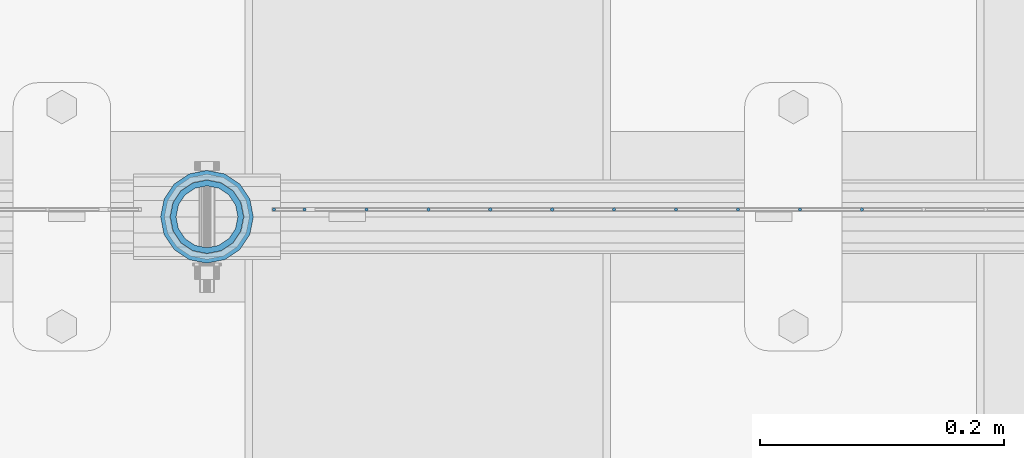
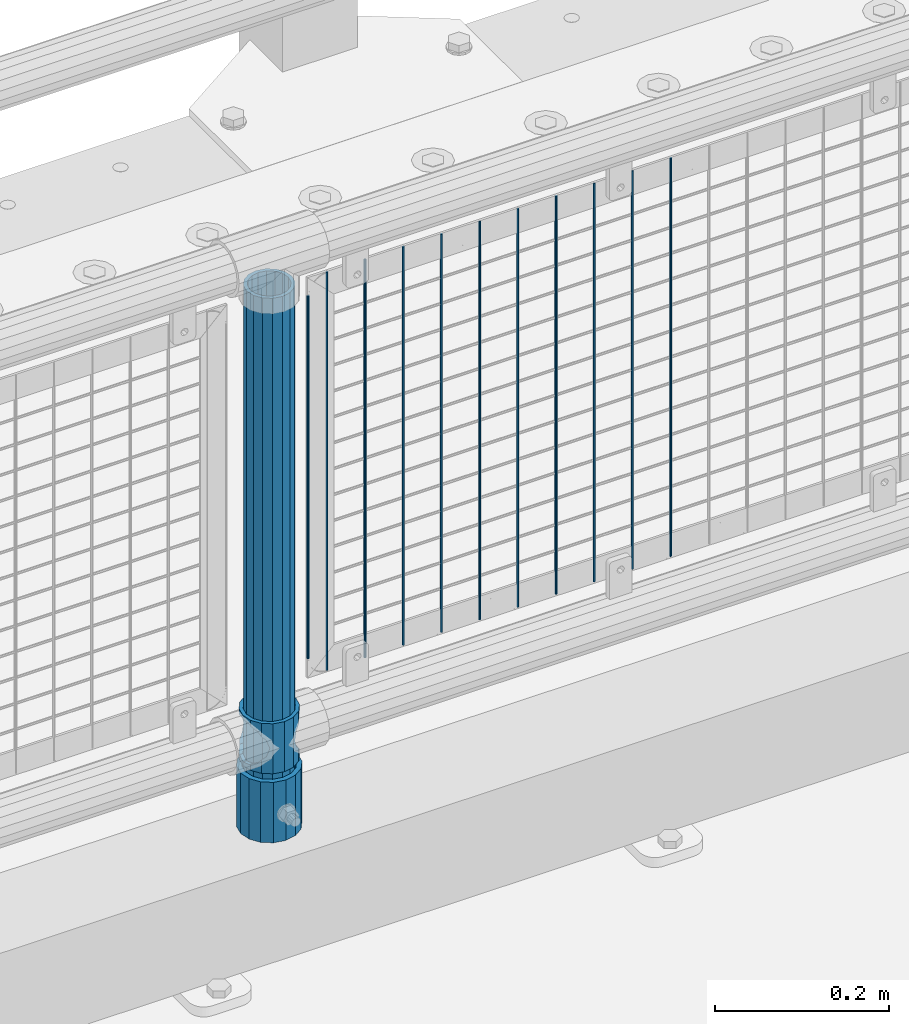
# One storey, part 88 of 270: 14 columns.
"""IFC2X3 building model written with IfcOpenShell, lengths in millimetres."""

from ifc_helpers import new_model, si_unit, frame, origin_with_axes, place, context, subcontext, project, spatial, faceted_brep, material, type_object, element, save


model = new_model("IFC2X3")

# Units and contexts
model_context = context("Model", 3, precision=1e-05, world=origin_with_axes())
body_context = subcontext(model_context, "Body", "Model", "MODEL_VIEW")
ifc_project = project(units=[si_unit("LENGTHUNIT", "METRE", prefix="MILLI"), si_unit("AREAUNIT", "SQUARE_METRE"), si_unit("VOLUMEUNIT", "CUBIC_METRE"), si_unit("MASSUNIT", "GRAM", prefix="KILO"), si_unit("TIMEUNIT", "SECOND"), si_unit("PLANEANGLEUNIT", "RADIAN"), si_unit("SOLIDANGLEUNIT", "STERADIAN"), si_unit("THERMODYNAMICTEMPERATUREUNIT", "DEGREE_CELSIUS"), si_unit("LUMINOUSINTENSITYUNIT", "LUMEN")], contexts=[model_context])

# Site, building, storey
site_placement = place(None, origin_with_axes())
site = spatial("IfcSite", under=ifc_project, at=site_placement, CompositionType="ELEMENT")
building_placement = place(site_placement, origin_with_axes())
building = spatial("IfcBuilding", under=site, at=building_placement, Name="Standard", CompositionType="ELEMENT")
storey_placement = place(building_placement, origin_with_axes())
storey = spatial("IfcBuildingStorey", under=building, at=storey_placement, Name="Undefined", CompositionType="ELEMENT", Elevation=0.0)

# Columns
ifc_material_1 = material()
column_type_1 = type_object("IfcColumnType", PredefinedType="NOTDEFINED")
column_1_placement = place(storey_placement, frame((10419.0, -16335.5, 168.02), z_axis=(-1.0, 0.0, 0.0), x_axis=(0.0, 0.0, 1.0)))
element("IfcColumn", 1, at=column_1_placement, inside=storey, type_object=column_type_1, material=ifc_material_1, context=body_context, shape_type="Brep", body=[
    faceted_brep([(0.0, -25.3500000000004, 0.0), (0.0, -23.4203461491616, 9.70102501045403), (760.0, -23.4203461491616, 9.70102501045403), (760.0, -25.3500000000004, 0.0), (0.0, -17.9251569030785, 17.9251569030785), (760.0, -17.9251569030785, 17.9251569030785), (0.0, -9.70102501045585, 23.4203461491597), (760.0, -9.70102501045585, 23.4203461491597), (0.0, 0.0, 25.3499999999985), (760.0, 0.0, 25.3499999999985), (0.0, 9.70102501045585, 23.4203461491597), (760.0, 9.70102501045585, 23.4203461491597), (0.0, 17.9251569030785, 17.9251569030785), (760.0, 17.9251569030785, 17.9251569030785), (0.0, 23.4203461491616, 9.70102501045403), (760.0, 23.4203461491616, 9.70102501045403), (0.0, 25.3500000000004, 0.0), (760.0, 25.3500000000004, 0.0), (0.0, 23.4203461491616, -9.70102501045403), (760.0, 23.4203461491616, -9.70102501045403), (0.0, 17.9251569030785, -17.9251569030785), (760.0, 17.9251569030785, -17.9251569030785), (0.0, 9.70102501045585, -23.4203461491597), (760.0, 9.70102501045585, -23.4203461491597), (0.0, 0.0, -25.3499999999985), (760.0, 0.0, -25.3499999999985), (0.0, -9.70102501045585, -23.4203461491597), (760.0, -9.70102501045585, -23.4203461491597), (0.0, -17.9251569030785, -17.9251569030785), (760.0, -17.9251569030785, -17.9251569030785), (0.0, -23.4203461491616, -9.70102501045403), (760.0, -23.4203461491616, -9.70102501045403), (0.0, -30.1499999999996, 0.0), (0.0, -27.8549679052157, -11.5379054858058), (760.0, -27.8549679052157, -11.5379054858058), (760.0, -30.1499999999996, 0.0), (0.0, -21.3192694527752, -21.3192694527752), (760.0, -21.3192694527752, -21.3192694527752), (0.0, -11.5379054858076, -27.8549679052157), (760.0, -11.5379054858076, -27.8549679052157), (0.0, 0.0, -30.1500000000015), (760.0, 0.0, -30.1500000000015), (0.0, 11.5379054858076, -27.8549679052157), (760.0, 11.5379054858076, -27.8549679052157), (0.0, 21.3192694527752, -21.3192694527752), (760.0, 21.3192694527752, -21.3192694527752), (0.0, 27.8549679052157, -11.5379054858058), (760.0, 27.8549679052157, -11.5379054858058), (0.0, 30.1499999999996, 0.0), (760.0, 30.1499999999996, 0.0), (0.0, 27.8549679052157, 11.5379054858058), (760.0, 27.8549679052157, 11.5379054858058), (0.0, 21.3192694527752, 21.3192694527752), (760.0, 21.3192694527752, 21.3192694527752), (0.0, 11.5379054858076, 27.8549679052157), (760.0, 11.5379054858076, 27.8549679052157), (0.0, 0.0, 30.1500000000015), (760.0, 0.0, 30.1500000000015), (0.0, -11.5379054858076, 27.8549679052157), (760.0, -11.5379054858076, 27.8549679052157), (0.0, -21.3192694527752, 21.3192694527752), (760.0, -21.3192694527752, 21.3192694527752), (0.0, -27.8549679052157, 11.5379054858058), (760.0, -27.8549679052157, 11.5379054858058)], [[[0, 1, 2, 3]], [[1, 4, 5, 2]], [[4, 6, 7, 5]], [[6, 8, 9, 7]], [[8, 10, 11, 9]], [[10, 12, 13, 11]], [[12, 14, 15, 13]], [[14, 16, 17, 15]], [[16, 18, 19, 17]], [[18, 20, 21, 19]], [[20, 22, 23, 21]], [[22, 24, 25, 23]], [[24, 26, 27, 25]], [[26, 28, 29, 27]], [[28, 30, 31, 29]], [[30, 0, 3, 31]], [[32, 33, 34, 35]], [[33, 36, 37, 34]], [[36, 38, 39, 37]], [[38, 40, 41, 39]], [[40, 42, 43, 41]], [[42, 44, 45, 43]], [[44, 46, 47, 45]], [[46, 48, 49, 47]], [[48, 50, 51, 49]], [[50, 52, 53, 51]], [[52, 54, 55, 53]], [[54, 56, 57, 55]], [[56, 58, 59, 57]], [[58, 60, 61, 59]], [[60, 62, 63, 61]], [[62, 32, 35, 63]], [[37, 39, 41, 43, 45, 47, 49, 51, 53, 55, 57, 59, 61, 63, 35, 34], [5, 7, 9, 11, 13, 15, 17, 19, 21, 23, 25, 27, 29, 31, 3, 2]], [[62, 60, 58, 56, 54, 52, 50, 48, 46, 44, 42, 40, 38, 36, 33, 32], [30, 28, 26, 24, 22, 20, 18, 16, 14, 12, 10, 8, 6, 4, 1, 0]]]),
])
column_type_2 = type_object("IfcColumnType", PredefinedType="NOTDEFINED")
column_2_placement = place(storey_placement, frame((10419.0, -16335.5, 168.02), z_axis=(0.0, 1.0, 0.0), x_axis=(0.0, 0.0, 1.0)))
element("IfcColumn", 2, at=column_2_placement, inside=storey, type_object=column_type_2, material=ifc_material_1, context=body_context, shape_type="Brep", body=[
    faceted_brep([(0.0, -31.75, 0.0), (0.0, -29.3331751572332, 12.1501989775916), (85.0, -29.3331751572332, 12.1501989775916), (85.0, -31.75, 0.0), (0.0, -22.4506403026717, 22.4506403026735), (85.0, -22.4506403026717, 22.4506403026735), (0.0, -12.1501989775934, 29.3331751572332), (85.0, -12.1501989775934, 29.3331751572332), (0.0, 0.0, 31.75), (85.0, 0.0, 31.75), (0.0, 12.1501989775934, 29.3331751572332), (85.0, 12.1501989775934, 29.3331751572332), (0.0, 22.4506403026717, 22.4506403026735), (85.0, 22.4506403026717, 22.4506403026735), (0.0, 29.3331751572332, 12.1501989775916), (85.0, 29.3331751572332, 12.1501989775916), (0.0, 31.75, 0.0), (85.0, 31.75, 0.0), (0.0, 29.3331751572332, -12.1501989775916), (85.0, 29.3331751572332, -12.1501989775916), (0.0, 22.4506403026717, -22.4506403026735), (85.0, 22.4506403026717, -22.4506403026735), (0.0, 12.1501989775934, -29.3331751572332), (85.0, 12.1501989775934, -29.3331751572332), (0.0, 0.0, -31.75), (85.0, 0.0, -31.75), (0.0, -12.1501989775934, -29.3331751572332), (85.0, -12.1501989775934, -29.3331751572332), (0.0, -22.4506403026717, -22.4506403026735), (85.0, -22.4506403026717, -22.4506403026735), (0.0, -29.3331751572332, -12.1501989775916), (85.0, -29.3331751572332, -12.1501989775916), (0.0, -38.0499999999993, 0.0), (0.0, -35.1536162120537, -14.561104601491), (85.0, -35.1536162120537, -14.561104601491), (85.0, -38.0499999999993, 0.0), (0.0, -26.9054130241493, -26.9054130241475), (85.0, -26.9054130241493, -26.9054130241475), (0.0, -14.5611046014928, -35.1536162120537), (85.0, -14.5611046014928, -35.1536162120537), (0.0, 0.0, -38.0499999999993), (85.0, 0.0, -38.0499999999993), (0.0, 14.5611046014928, -35.1536162120537), (85.0, 14.5611046014928, -35.1536162120537), (0.0, 26.9054130241493, -26.9054130241475), (85.0, 26.9054130241493, -26.9054130241475), (0.0, 35.1536162120537, -14.561104601491), (85.0, 35.1536162120537, -14.561104601491), (0.0, 38.0499999999993, 0.0), (85.0, 38.0499999999993, 0.0), (0.0, 35.1536162120537, 14.561104601491), (85.0, 35.1536162120537, 14.561104601491), (0.0, 26.9054130241493, 26.9054130241475), (85.0, 26.9054130241493, 26.9054130241475), (0.0, 14.5611046014928, 35.1536162120537), (85.0, 14.5611046014928, 35.1536162120537), (0.0, 0.0, 38.0499999999993), (85.0, 0.0, 38.0499999999993), (0.0, -14.5611046014928, 35.1536162120537), (85.0, -14.5611046014928, 35.1536162120537), (0.0, -26.9054130241493, 26.9054130241475), (85.0, -26.9054130241493, 26.9054130241475), (0.0, -35.1536162120537, 14.561104601491), (85.0, -35.1536162120537, 14.561104601491)], [[[0, 1, 2, 3]], [[1, 4, 5, 2]], [[4, 6, 7, 5]], [[6, 8, 9, 7]], [[8, 10, 11, 9]], [[10, 12, 13, 11]], [[12, 14, 15, 13]], [[14, 16, 17, 15]], [[16, 18, 19, 17]], [[18, 20, 21, 19]], [[20, 22, 23, 21]], [[22, 24, 25, 23]], [[24, 26, 27, 25]], [[26, 28, 29, 27]], [[28, 30, 31, 29]], [[30, 0, 3, 31]], [[32, 33, 34, 35]], [[33, 36, 37, 34]], [[36, 38, 39, 37]], [[38, 40, 41, 39]], [[40, 42, 43, 41]], [[42, 44, 45, 43]], [[44, 46, 47, 45]], [[46, 48, 49, 47]], [[48, 50, 51, 49]], [[50, 52, 53, 51]], [[52, 54, 55, 53]], [[54, 56, 57, 55]], [[56, 58, 59, 57]], [[58, 60, 61, 59]], [[60, 62, 63, 61]], [[62, 32, 35, 63]], [[37, 39, 41, 43, 45, 47, 49, 51, 53, 55, 57, 59, 61, 63, 35, 34], [5, 7, 9, 11, 13, 15, 17, 19, 21, 23, 25, 27, 29, 31, 3, 2]], [[62, 60, 58, 56, 54, 52, 50, 48, 46, 44, 42, 40, 38, 36, 33, 32], [30, 28, 26, 24, 22, 20, 18, 16, 14, 12, 10, 8, 6, 4, 1, 0]]]),
])
ifc_material_2 = material(Name="Misc_Undefined")
column_type_3 = type_object("IfcColumnType", PredefinedType="NOTDEFINED")
column_3_placement = place(storey_placement, frame((10419.0, -16335.5, 263.02), z_axis=(-1.0, 0.0, 0.0), x_axis=(0.0, 0.0, 1.0)))
element("IfcColumn", 3, at=column_3_placement, inside=storey, type_object=column_type_3, material=ifc_material_2, context=body_context, shape_type="Brep", body=[
    faceted_brep([(63.1897438117183, 11.6144421722802, -32.8397438117208), (63.1897438117183, 11.6144421722802, -28.0397438117179), (56.6106908090125, 21.4606908090118, -21.46069080901), (56.6106908090125, 21.4606908090118, -27.1226768591005), (61.9623795176767, 13.4513226476338, -32.4743655677703), (46.7644421722812, 28.0397438117179, -11.614442172282), (46.7644421722812, 28.0397438117179, -20.0882031229812), (51.5310424080071, 24.8548033587067, -24.8548033587067), (35.1500000000015, 30.35, 0.0), (35.1500000000008, 30.3500000000004, -16.6306603983612), (23.5355578277203, 28.0397438117179, -11.614442172282), (23.5355578277203, 28.0397438117179, -20.0882031229812), (18.7689575919954, 24.8548033587067, -24.8548033587067), (13.689309190989, 21.4606908090118, -21.46069080901), (13.689309190989, 21.4606908090118, -27.1226768591005), (8.33762048232484, 13.4513226476338, -32.4743655677703), (7.11025618828324, 11.6144421722802, -28.0397438117179), (7.11025618828324, 11.6144421722802, -32.8397438117208), (4.80000000000075, 0.0, -30.3499999999985), (4.80000000000075, 0.0, -35.1500000000015), (7.11025618828319, -11.6144421722802, -28.0397438117179), (7.11025618828319, -11.6144421722802, -32.8397438117172), (13.689309190989, -21.4606908090118, -21.46069080901), (13.689309190989, -21.4606908090118, -27.1226768591041), (8.33762048232484, -13.4513226476338, -32.4743655677703), (23.5355578277203, -28.0397438117179, -11.614442172282), (23.5355578277203, -28.0397438117179, -20.0882031229885), (18.7689575919954, -24.8548033587067, -24.8548033587067), (35.1500000000015, -30.35, 0.0), (35.1500000000008, -30.3500000000004, -16.6306603983721), (46.7644421722812, -28.0397438117179, -11.614442172282), (46.7644421722812, -28.0397438117179, -20.0882031229885), (51.5310424080071, -24.8548033587067, -24.8548033587067), (56.6106908090125, -21.4606908090118, -21.46069080901), (56.6106908090125, -21.4606908090118, -27.1226768591041), (61.9623795176767, -13.4513226476338, -32.4743655677703), (63.1897438117183, -11.6144421722802, -28.0397438117179), (63.1897438117183, -11.6144421722802, -32.8397438117172), (65.5000000000008, 0.0, -30.3499999999985), (65.5000000000008, 0.0, -35.1500000000015), (0.0, -28.0397438117179, -11.614442172282), (0.0, -30.3500000000004, 0.0), (0.0, -21.4606908090118, -21.46069080901), (0.0, -11.6144421722802, -28.0397438117179), (0.0, 0.0, -30.3499999999985), (0.0, 11.6144421722802, -28.0397438117179), (0.0, 21.4606908090118, -21.46069080901), (0.0, 28.0397438117179, -11.614442172282), (0.0, 30.3500000000004, 0.0), (0.0, 28.0397438117179, 11.614442172282), (23.5355578277192, 28.0397438117179, 11.614442172282), (0.0, 21.4606908090118, 21.46069080901), (13.6893091909879, 21.4606908090118, 21.46069080901), (0.0, 11.6144421722802, 28.0397438117179), (7.11025618828211, 11.6144421722802, 28.0397438117179), (0.0, 0.0, 30.3499999999985), (4.79999999999961, 0.0, 30.3499999999985), (0.0, -11.6144421722802, 28.0397438117179), (7.11025618828205, -11.6144421722802, 28.0397438117179), (0.0, -21.4606908090118, 21.46069080901), (13.6893091909879, -21.4606908090118, 21.46069080901), (0.0, -28.0397438117179, 11.614442172282), (23.5355578277191, -28.0397438117179, 11.614442172282), (0.0, -32.4743655677721, 13.4513226476338), (0.0, -35.1499999999996, 0.0), (70.2999999999993, -35.1499999999996, 0.0), (70.2999999999993, -32.4743655677721, 13.4513226476338), (0.0, 13.4513226476338, -32.4743655677703), (0.0, 24.8548033587067, -24.8548033587067), (0.0, 0.0, -35.1499999999996), (0.0, -13.4513226476338, -32.4743655677703), (0.0, -24.8548033587067, -24.8548033587067), (0.0, -24.8548033587067, 24.8548033587067), (0.0, -13.4513226476338, 32.4743655677703), (0.0, 0.0, 35.1499999999996), (0.0, 13.4513226476338, 32.4743655677703), (0.0, 24.8548033587067, 24.8548033587067), (0.0, 32.4743655677721, 13.4513226476338), (0.0, 35.1499999999996, 0.0), (0.0, 32.4743655677721, -13.4513226476338), (0.0, -32.4743655677721, -13.4513226476338), (70.2999999999993, 32.4743655677721, 13.4513226476338), (70.2999999999993, 35.1499999999996, 0.0), (70.2999999999993, 32.4743655677721, -13.4513226476338), (70.2999999999993, 24.8548033587067, -24.8548033587067), (70.2999999999993, 13.4513226476338, -32.4743655677703), (70.2999999999993, 0.0, -35.1500000000015), (70.2999999999993, -13.4513226476338, -32.4743655677703), (70.2999999999993, -24.8548033587067, -24.8548033587067), (70.2999999999993, -32.4743655677721, -13.4513226476338), (70.2999999999993, 28.0397438117179, 11.614442172282), (70.2999999999993, 21.4606908090118, 21.46069080901), (56.6106908090114, 21.4606908090118, 21.46069080901), (46.7644421722801, 28.0397438117179, 11.614442172282), (70.2999999999993, 11.6144421722802, 28.0397438117179), (63.1897438117172, 11.6144421722802, 28.0397438117179), (70.2999999999993, 0.0, 30.3499999999985), (65.4999999999997, 0.0, 30.3499999999985), (70.2999999999993, -11.6144421722802, 28.0397438117179), (63.1897438117172, -11.6144421722802, 28.0397438117179), (70.2999999999993, -21.4606908090118, 21.46069080901), (56.6106908090114, -21.4606908090118, 21.46069080901), (70.2999999999993, -28.0397438117179, 11.614442172282), (46.7644421722801, -28.0397438117179, 11.614442172282), (70.2999999999993, -11.6144421722802, -28.0397438117179), (70.2999999999993, 0.0, -30.3499999999985), (70.2999999999993, -21.4606908090118, -21.46069080901), (70.2999999999993, -28.0397438117179, -11.614442172282), (70.2999999999993, -30.3500000000004, 0.0), (70.2999999999993, 24.8548033587067, 24.8548033587067), (70.2999999999993, 13.4513226476338, 32.4743655677703), (70.2999999999993, 0.0, 35.1500000000015), (70.2999999999993, -13.4513226476338, 32.4743655677703), (70.2999999999993, -24.8548033587067, 24.8548033587067), (70.2999999999993, 30.3500000000004, 0.0), (70.2999999999993, 28.0397438117179, -11.614442172282), (70.2999999999993, 21.4606908090118, -21.46069080901), (70.2999999999993, 11.6144421722802, -28.0397438117179), (61.9623795176767, 13.4513226476338, 32.4743655677703), (51.5310424080039, 24.8548033587067, 24.8548033587067), (56.6106908090114, 21.4606908090118, 27.1226768591041), (65.4999999999997, 0.0, 35.1500000000015), (63.1897438117172, 11.6144421722802, 32.8397438117172), (63.1897438117172, -11.6144421722802, 32.8397438117172), (61.9623795176767, -13.4513226476338, 32.4743655677703), (56.6106908090114, -21.4606908090118, 27.1226768591077), (51.5310424080071, -24.8548033587067, 24.8548033587067), (18.7689575919954, -24.8548033587067, 24.8548033587067), (46.7644421722801, -28.0397438117179, 20.0882031229849), (35.1499999999996, -30.3500000000004, 16.6306603983649), (23.5355578277191, -28.0397438117179, 20.0882031229849), (8.33762048232262, -13.4513226476338, 32.4743655677703), (13.6893091909879, -21.4606908090118, 27.1226768591077), (4.79999999999961, 0.0, 35.1500000000015), (7.11025618828205, -11.6144421722802, 32.8397438117172), (7.11025618828211, 11.6144421722802, 32.8397438117172), (8.33762048232262, 13.4513226476338, 32.4743655677703), (13.6893091909879, 21.4606908090118, 27.1226768591041), (18.7689575919954, 24.8548033587067, 24.8548033587067), (23.5355578277192, 28.0397438117179, 20.0882031229885), (35.1499999999996, 30.3500000000004, 16.6306603983685), (46.7644421722801, 28.0397438117179, 20.0882031229885)], [[[0, 1, 2, 3, 4]], [[3, 2, 5, 6, 7]], [[6, 5, 8, 9]], [[9, 8, 10, 11]], [[12, 11, 10, 13, 14]], [[15, 14, 13, 16, 17]], [[17, 16, 18, 19]], [[19, 18, 20, 21]], [[21, 20, 22, 23, 24]], [[23, 22, 25, 26, 27]], [[26, 25, 28, 29]], [[29, 28, 30, 31]], [[32, 31, 30, 33, 34]], [[35, 34, 33, 36, 37]], [[37, 36, 38, 39]], [[39, 38, 1, 0]], [[40, 41, 28, 25]], [[42, 40, 25, 22]], [[43, 42, 22, 20]], [[44, 43, 20, 18]], [[45, 44, 18, 16]], [[46, 45, 16, 13]], [[47, 46, 13, 10]], [[48, 47, 10, 8]], [[49, 48, 8, 50]], [[51, 49, 50, 52]], [[53, 51, 52, 54]], [[55, 53, 54, 56]], [[57, 55, 56, 58]], [[59, 57, 58, 60]], [[61, 59, 60, 62]], [[41, 61, 62, 28]], [[63, 64, 65, 66]], [[67, 68, 12, 14, 15]], [[69, 67, 15, 17, 19]], [[24, 70, 69, 19, 21]], [[27, 71, 70, 24, 23]], [[63, 72, 73, 74, 75, 76, 77, 78, 79, 68, 67, 69, 70, 71, 80, 64], [40, 42, 43, 44, 45, 46, 47, 48, 49, 51, 53, 55, 57, 59, 61, 41]], [[78, 77, 81, 82]], [[79, 78, 82, 83]], [[68, 79, 83, 84, 7, 6, 9, 11, 12]], [[7, 84, 85, 4, 3]], [[4, 85, 86, 39, 0]], [[87, 88, 32, 34, 35]], [[86, 87, 35, 37, 39]], [[29, 31, 32, 88, 89, 80, 71, 27, 26]], [[64, 80, 89, 65]], [[90, 91, 92, 93]], [[91, 94, 95, 92]], [[94, 96, 97, 95]], [[96, 98, 99, 97]], [[98, 100, 101, 99]], [[100, 102, 103, 101]], [[104, 105, 38, 36]], [[106, 104, 36, 33]], [[107, 106, 33, 30]], [[108, 107, 30, 28]], [[102, 108, 28, 103]], [[88, 87, 86, 85, 84, 83, 82, 81, 109, 110, 111, 112, 113, 66, 65, 89], [100, 98, 96, 94, 91, 90, 114, 115, 116, 117, 105, 104, 106, 107, 108, 102]], [[118, 110, 109, 119, 120]], [[121, 111, 110, 118, 122]], [[112, 111, 121, 123, 124]], [[113, 112, 124, 125, 126]], [[127, 72, 63, 66, 113, 126, 128, 129, 130]], [[131, 73, 72, 127, 132]], [[133, 74, 73, 131, 134]], [[75, 74, 133, 135, 136]], [[76, 75, 136, 137, 138]], [[119, 109, 81, 77, 76, 138, 139, 140, 141]], [[92, 120, 119, 141, 93]], [[95, 122, 118, 120, 92]], [[97, 121, 122, 95]], [[99, 123, 121, 97]], [[101, 125, 124, 123, 99]], [[103, 128, 126, 125, 101]], [[28, 129, 128, 103]], [[62, 130, 129, 28]], [[60, 132, 127, 130, 62]], [[58, 134, 131, 132, 60]], [[56, 133, 134, 58]], [[54, 135, 133, 56]], [[52, 137, 136, 135, 54]], [[50, 139, 138, 137, 52]], [[8, 140, 139, 50]], [[93, 141, 140, 8]], [[114, 90, 93, 8]], [[115, 114, 8, 5]], [[116, 115, 5, 2]], [[117, 116, 2, 1]], [[105, 117, 1, 38]]]),
])
column_type_4 = type_object("IfcColumnType", Name="D3", PredefinedType="NOTDEFINED")
for number, where, z_axis, x_axis in (
    (4, (10956.137, -16329.5, 353.02), (-1.0, 0.0, 0.0), (0.0, 0.0, 1.0)),
    (5, (10905.344, -16329.5, 353.02), (-1.0, 0.0, 0.0), (0.0, 0.0, 1.0)),
    (6, (10854.551, -16329.5, 353.02), (-1.0, 0.0, 0.0), (0.0, 0.0, 1.0)),
    (7, (10803.758, -16329.5, 353.02), (-1.0, 0.0, 0.0), (0.0, 0.0, 1.0)),
    (8, (10752.965, -16329.5, 353.02), (-1.0, 0.0, 0.0), (0.0, 0.0, 1.0)),
    (9, (10702.172, -16329.5, 353.02), (-1.0, 0.0, 0.0), (0.0, 0.0, 1.0)),
    (10, (10651.379, -16329.5, 353.02), (-1.0, 0.0, 0.0), (0.0, 0.0, 1.0)),
    (11, (10600.586, -16329.5, 353.02), (-1.0, 0.0, 0.0), (0.0, 0.0, 1.0)),
    (12, (10549.793, -16329.5, 353.02), (-1.0, 0.0, 0.0), (0.0, 0.0, 1.0)),
):
    element("IfcColumn", number, at=place(storey_placement, frame(where, z_axis=z_axis, x_axis=x_axis)), inside=storey, type_object=column_type_4, material=ifc_material_2, ObjectType="D3", context=body_context, shape_type="Brep", body=[
        faceted_brep([(0.0, -1.5, 0.0), (0.0, -0.75, -1.29903810567669), (560.0, -0.75, -1.29903810567703), (560.0, -1.5, 0.0), (0.0, 0.75, -1.29903810567669), (560.0, 0.75, -1.29903810567703), (0.0, 1.5, 0.0), (560.0, 1.5, 0.0), (0.0, 0.75, 1.29903810567669), (560.0, 0.75, 1.29903810567703), (0.0, -0.75, 1.29903810567669), (560.0, -0.75, 1.29903810567703)], [[[0, 1, 2, 3]], [[1, 4, 5, 2]], [[4, 6, 7, 5]], [[6, 8, 9, 7]], [[8, 10, 11, 9]], [[10, 0, 3, 11]], [[5, 7, 9, 11, 3, 2]], [[10, 8, 6, 4, 1, 0]]]),
    ])
column_4_placement = place(storey_placement, frame((10474.0, -16329.5, 378.02), z_axis=(-1.0, 0.0, 0.0), x_axis=(0.0, 0.0, 1.0)))
element("IfcColumn", 13, at=column_4_placement, inside=storey, type_object=column_type_4, material=ifc_material_2, ObjectType="D3", context=body_context, shape_type="Brep", body=[
    faceted_brep([(0.0, -1.5, 0.0), (0.0, -0.75, -1.29903810567669), (510.0, -0.75, -1.29903810567703), (510.0, -1.5, 0.0), (0.0, 0.75, -1.29903810567669), (510.0, 0.75, -1.29903810567703), (0.0, 1.5, 0.0), (510.0, 1.5, 0.0), (0.0, 0.75, 1.29903810567669), (510.0, 0.75, 1.29903810567703), (0.0, -0.75, 1.29903810567669), (510.0, -0.75, 1.29903810567703)], [[[0, 1, 2, 3]], [[1, 4, 5, 2]], [[4, 6, 7, 5]], [[6, 8, 9, 7]], [[8, 10, 11, 9]], [[10, 0, 3, 11]], [[5, 7, 9, 11, 3, 2]], [[10, 8, 6, 4, 1, 0]]]),
])
column_5_placement = place(storey_placement, frame((10499.0, -16329.5, 353.02), z_axis=(-1.0, 0.0, 0.0), x_axis=(0.0, 0.0, 1.0)))
element("IfcColumn", 14, at=column_5_placement, inside=storey, type_object=column_type_4, material=ifc_material_2, ObjectType="D3", context=body_context, shape_type="Brep", body=[
    faceted_brep([(0.0, -1.5, 0.0), (0.0, -0.75, -1.29903810567669), (560.0, -0.75, -1.29903810567703), (560.0, -1.5, 0.0), (0.0, 0.75, -1.29903810567669), (560.0, 0.75, -1.29903810567703), (0.0, 1.5, 0.0), (560.0, 1.5, 0.0), (0.0, 0.75, 1.29903810567669), (560.0, 0.75, 1.29903810567703), (0.0, -0.75, 1.29903810567669), (560.0, -0.75, 1.29903810567703)], [[[0, 1, 2, 3]], [[1, 4, 5, 2]], [[4, 6, 7, 5]], [[6, 8, 9, 7]], [[8, 10, 11, 9]], [[10, 0, 3, 11]], [[5, 7, 9, 11, 3, 2]], [[10, 8, 6, 4, 1, 0]]]),
])

save(model, "model.ifc")
